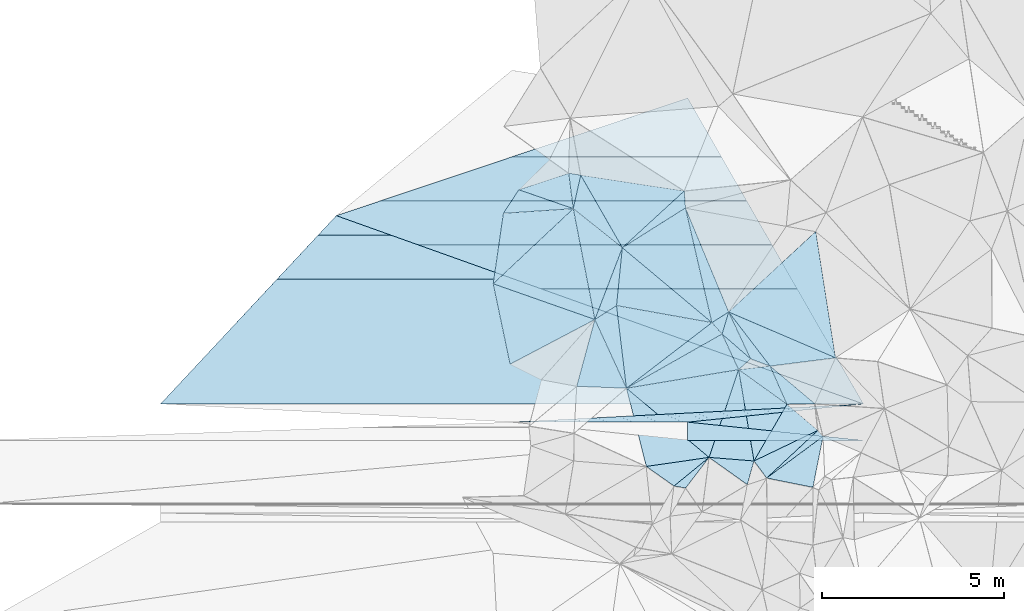
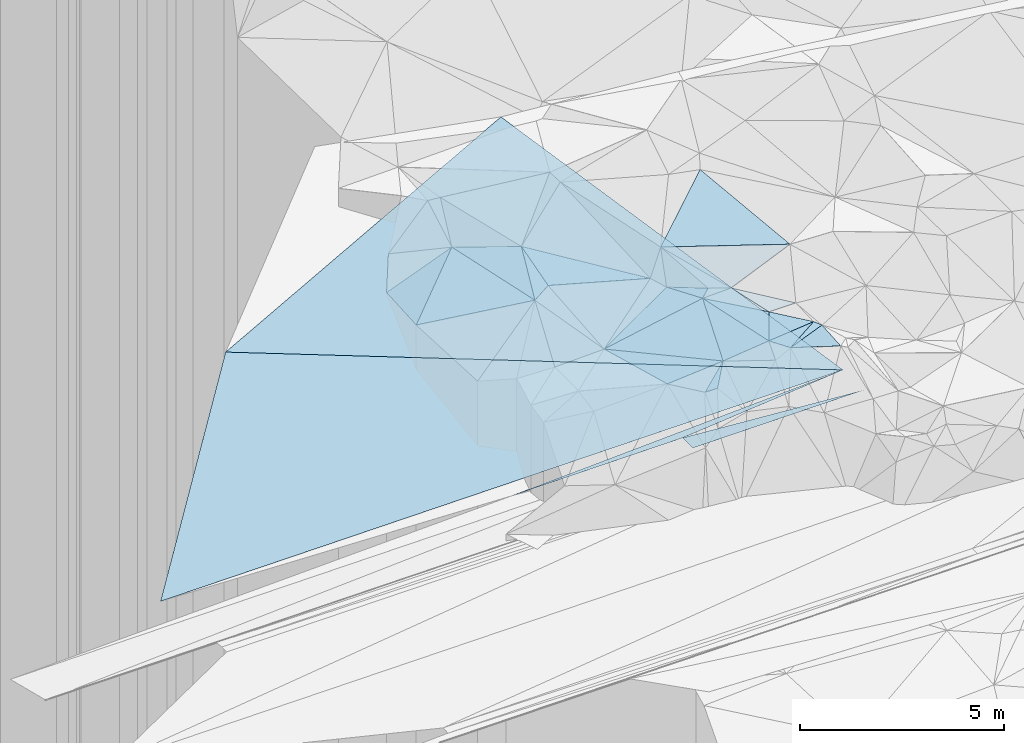
# One storey, part 67 of 275: 50 plates.
"""IFC2X3 building model written with IfcOpenShell, lengths in millimetres."""

from ifc_helpers import new_model, si_unit, frame, origin_with_axes, place, context, subcontext, project, spatial, polyline, outline, extrude, material, type_object, element, save


model = new_model("IFC2X3")

# Units and contexts
model_context = context("Model", 3, precision=1e-05, world=origin_with_axes())
body_context = subcontext(model_context, "Body", "Model", "MODEL_VIEW")
ifc_project = project(units=[si_unit("LENGTHUNIT", "METRE", prefix="MILLI"), si_unit("AREAUNIT", "SQUARE_METRE"), si_unit("VOLUMEUNIT", "CUBIC_METRE"), si_unit("MASSUNIT", "GRAM", prefix="KILO"), si_unit("TIMEUNIT", "SECOND"), si_unit("PLANEANGLEUNIT", "RADIAN"), si_unit("SOLIDANGLEUNIT", "STERADIAN"), si_unit("THERMODYNAMICTEMPERATUREUNIT", "DEGREE_CELSIUS"), si_unit("LUMINOUSINTENSITYUNIT", "LUMEN")], contexts=[model_context])

# Site, building, storey
site_placement = place(None, origin_with_axes())
site = spatial("IfcSite", under=ifc_project, at=site_placement, CompositionType="ELEMENT")
building_placement = place(site_placement, origin_with_axes())
building = spatial("IfcBuilding", under=site, at=building_placement, Name="Undefined", CompositionType="ELEMENT")
storey_placement = place(building_placement, origin_with_axes())
storey = spatial("IfcBuildingStorey", under=building, at=storey_placement, Name="Undefined", CompositionType="ELEMENT", Elevation=0.0)

# Plates
ifc_material = material()
plate_type_1 = type_object("IfcPlateType", PredefinedType="NOTDEFINED")
for number, where, z_axis, x_axis, name in (
    (1, (-129444.335760061, 69294.3090173792, 48443.6810089496), (0.00832550512650313, -4.76525014343269e-07, -0.999965342381505), (-0.994665412446994, -0.102820903085224, -0.00828125415566605), "00_PR"),
    (2, (-129444.335760061, 69294.3090173792, 48443.6810089496), (0.00832550512650313, -4.76525014343269e-07, -0.999965342381505), (-0.994665412446994, -0.102820903085224, -0.00828125415566605), "00_PR"),
    (3, (-129444.335760061, 69294.3090173792, 48443.6810089496), (0.00832550512650313, -4.76525014343269e-07, -0.999965342381505), (-0.994665412446994, -0.102820903085224, -0.00828125415566605), "00_PR"),
):
    element("IfcPlate", number, at=place(storey_placement, frame(where, z_axis=z_axis, x_axis=x_axis)), inside=storey, type_object=plate_type_1, material=ifc_material, Name=name, context=body_context, shape_type="SweptSolid", body=[
        extrude(outline(polyline([(0.0, 0.0), (4860.13330078125, -1.09284883365035e-08), (9668.8271484375, 497.347320556641), (0.0, 0.0)])), frame((-8.85201319254618e-08, 2.18876761149539e-07, -0.5000001331573), z_axis=(0.0, 0.0, 1.0), x_axis=(1.0, 0.0, 0.0)), (0.0, 0.0, 1.0), 1.0),
    ])
plate_type_2 = type_object("IfcPlateType", PredefinedType="NOTDEFINED")
plate_1_placement = place(storey_placement, frame((-133151.568710106, 71824.4536752865, 51889.7082125134), z_axis=(0.578569093147752, 0.569869113096198, -0.583529775069911), x_axis=(0.384124780186337, -0.821500114876662, -0.421409200782837)))
element("IfcPlate", 4, at=plate_1_placement, inside=storey, type_object=plate_type_2, material=ifc_material, Name="00", context=body_context, shape_type="SweptSolid", body=[
    extrude(outline(polyline([(0.0, 0.0), (1566.17370605469, -5.5297277867794e-10), (751.832336425781, 652.800231933594), (0.0, 0.0)])), frame((-8.85201319254618e-08, 2.18876761149539e-07, -0.5000001331573), z_axis=(0.0, 0.0, 1.0), x_axis=(1.0, 0.0, 0.0)), (0.0, 0.0, 1.0), 1.0),
])
plate_type_3 = type_object("IfcPlateType", PredefinedType="NOTDEFINED")
plate_2_placement = place(storey_placement, frame((-136832.977407611, 71618.2938263734, 51709.5212023326), z_axis=(-0.156077399561047, 0.242364993441896, -0.957548461071381), x_axis=(0.840750067986882, 0.541423423191178, 1.24122210420389e-10)))
element("IfcPlate", 5, at=plate_2_placement, inside=storey, type_object=plate_type_3, material=ifc_material, Name="00", context=body_context, shape_type="SweptSolid", body=[
    extrude(outline(polyline([(0.0, 0.0), (708.590148925781, 6.98491930961609e-10), (-293.258392333984, 2150.74389648438), (0.0, 0.0)])), frame((-8.85201319254618e-08, 2.18876761149539e-07, -0.5000001331573), z_axis=(0.0, 0.0, 1.0), x_axis=(1.0, 0.0, 0.0)), (0.0, 0.0, 1.0), 1.0),
])
plate_type_4 = type_object("IfcPlateType", PredefinedType="NOTDEFINED")
plate_3_placement = place(storey_placement, frame((-139629.114113772, 72601.3486087522, 51349.5338180711), z_axis=(0.308443297718231, -0.188807443048331, -0.932316728125295), x_axis=(0.141282109827819, 0.978326261785137, -0.151383919040691)))
element("IfcPlate", 6, at=plate_3_placement, inside=storey, type_object=plate_type_4, material=ifc_material, Name="00", context=body_context, shape_type="SweptSolid", body=[
    extrude(outline(polyline([(0.0, 0.0), (1981.71643066406, -9.42964106798172e-09), (2286.40185546875, 1997.74047851563), (0.0, 0.0)])), frame((-8.85201319254618e-08, 2.18876761149539e-07, -0.5000001331573), z_axis=(0.0, 0.0, 1.0), x_axis=(1.0, 0.0, 0.0)), (0.0, 0.0, 1.0), 1.0),
])
plate_type_5 = type_object("IfcPlateType", PredefinedType="NOTDEFINED")
for number, where, z_axis, x_axis, name in (
    (7, (-134278.542476216, 68794.5856960498, 48403.4330086572), (0.00832550512650313, -4.76525014343269e-07, -0.999965342381505), (0.994653635899512, -0.102934762941165, 0.00828125413975662), "00_PR"),
    (8, (-134278.542476216, 68794.5856960498, 48403.4330086572), (0.00832550512650313, -4.76525014343269e-07, -0.999965342381505), (0.994653635899512, -0.102934762941165, 0.00828125413975662), "00_PR"),
    (9, (-134278.542476216, 68794.5856960498, 48403.4330086572), (0.00832550512650313, -4.76525014343269e-07, -0.999965342381505), (0.994653635899512, -0.102934762941165, 0.00828125413975662), "00_PR"),
):
    element("IfcPlate", number, at=place(storey_placement, frame(where, z_axis=z_axis, x_axis=x_axis)), inside=storey, type_object=plate_type_5, material=ifc_material, Name=name, context=body_context, shape_type="SweptSolid", body=[
        extrude(outline(polyline([(0.0, 0.0), (4860.13330078125, -1.09284883365035e-08), (51.4388885498047, 497.347015380859), (0.0, 0.0)])), frame((-8.85201319254618e-08, 2.18876761149539e-07, -0.5000001331573), z_axis=(0.0, 0.0, 1.0), x_axis=(1.0, 0.0, 0.0)), (0.0, 0.0, 1.0), 1.0),
    ])
plate_type_6 = type_object("IfcPlateType", PredefinedType="NOTDEFINED")
plate_4_placement = place(storey_placement, frame((-132455.381157078, 67725.8258750674, 51319.5189506948), z_axis=(-0.257117366696201, -0.0910848269011181, -0.962078070663501), x_axis=(0.491212129687277, 0.845027332798837, -0.211280501871263)))
element("IfcPlate", 10, at=plate_4_placement, inside=storey, type_object=plate_type_6, material=ifc_material, Name="00", context=body_context, shape_type="SweptSolid", body=[
    extrude(outline(polyline([(0.0, 0.0), (1845.88732910156, 1.36205926537514e-08), (1693.00695800781, 1114.59753417969), (0.0, 0.0)])), frame((-8.85201319254618e-08, 2.18876761149539e-07, -0.5000001331573), z_axis=(0.0, 0.0, 1.0), x_axis=(1.0, 0.0, 0.0)), (0.0, 0.0, 1.0), 1.0),
])
plate_type_7 = type_object("IfcPlateType", PredefinedType="NOTDEFINED")
plate_5_placement = place(storey_placement, frame((-130556.349028885, 68401.3227740387, 50719.5199078316), z_axis=(-0.21672475804509, -0.176393568784046, -0.960164406829333), x_axis=(-0.189118695865837, -0.95732243317476, 0.21855863701616)))
element("IfcPlate", 11, at=plate_5_placement, inside=storey, type_object=plate_type_7, material=ifc_material, Name="00", context=body_context, shape_type="SweptSolid", body=[
    extrude(outline(polyline([(0.0, 0.0), (1464.13793945313, -5.76255843043327e-09), (1510.92321777344, 1319.66333007813), (0.0, 0.0)])), frame((-8.85201319254618e-08, 2.18876761149539e-07, -0.5000001331573), z_axis=(0.0, 0.0, 1.0), x_axis=(1.0, 0.0, 0.0)), (0.0, 0.0, 1.0), 1.0),
])
plate_type_8 = type_object("IfcPlateType", PredefinedType="NOTDEFINED")
plate_6_placement = place(storey_placement, frame((-133613.467629506, 71532.7080362273, 51289.5076855455), z_axis=(-0.138507740364616, 0.106817498638844, -0.984583987196435), x_axis=(-0.972387778428098, 0.173877071909719, 0.155655941832529)))
element("IfcPlate", 12, at=plate_6_placement, inside=storey, type_object=plate_type_8, material=ifc_material, Name="00", context=body_context, shape_type="SweptSolid", body=[
    extrude(outline(polyline([(0.0, 0.0), (2698.2587890625, -4.40195435658097e-09), (2842.12915039063, 1599.37524414063), (0.0, 0.0)])), frame((-8.85201319254618e-08, 2.18876761149539e-07, -0.5000001331573), z_axis=(0.0, 0.0, 1.0), x_axis=(1.0, 0.0, 0.0)), (0.0, 0.0, 1.0), 1.0),
])
plate_type_9 = type_object("IfcPlateType", PredefinedType="NOTDEFINED")
for number, where, z_axis, x_axis, name in (
    (13, (-134278.031319056, 77711.906399942, 52612.0347901704), (0.00747221277555471, 0.447200796920443, -0.894402377719311), (0.457576437903009, -0.79682143765692, -0.394587632809689), "00_PR"),
    (14, (-134278.031319056, 77711.906399942, 52612.0347901704), (0.00747221277555471, 0.447200796920443, -0.894402377719311), (0.457576437903009, -0.79682143765692, -0.394587632809689), "00_PR"),
    (15, (-134278.031319056, 77711.906399942, 52612.0347901704), (0.00747221277555471, 0.447200796920443, -0.894402377719311), (0.457576437903009, -0.79682143765692, -0.394587632809689), "00_PR"),
):
    element("IfcPlate", number, at=place(storey_placement, frame(where, z_axis=z_axis, x_axis=x_axis)), inside=storey, type_object=plate_type_9, material=ifc_material, Name=name, context=body_context, shape_type="SweptSolid", body=[
        extrude(outline(polyline([(0.0, 0.0), (10563.6884765625, 9.62900230661035e-08), (-1175.76281738281, 10268.96875), (0.0, 0.0)])), frame((-8.85201319254618e-08, 2.18876761149539e-07, -0.5000001331573), z_axis=(0.0, 0.0, 1.0), x_axis=(1.0, 0.0, 0.0)), (0.0, 0.0, 1.0), 1.0),
    ])
plate_type_10 = type_object("IfcPlateType", PredefinedType="NOTDEFINED")
for number, where, z_axis, x_axis, name in (
    (16, (-143946.572280143, 74476.4051419111, 50913.5097885853), (0.00747221277555471, 0.447200796920443, -0.894402377719311), (0.929809253918933, -0.332235179916425, -0.158349412858456), "00_PR"),
    (17, (-143946.572280143, 74476.4051419111, 50913.5097885853), (0.00747221277555471, 0.447200796920443, -0.894402377719311), (0.929809253918933, -0.332235179916425, -0.158349412858456), "00_PR"),
    (18, (-143946.572280143, 74476.4051419111, 50913.5097885853), (0.00747221277555471, 0.447200796920443, -0.894402377719311), (0.929809253918933, -0.332235179916425, -0.158349412858456), "00_PR"),
):
    element("IfcPlate", number, at=place(storey_placement, frame(where, z_axis=z_axis, x_axis=x_axis)), inside=storey, type_object=plate_type_10, material=ifc_material, Name=name, context=body_context, shape_type="SweptSolid", body=[
        extrude(outline(polyline([(0.0, 0.0), (15597.0009765625, 2.149427018594e-07), (-2357.32592773438, 7181.6728515625), (0.0, 0.0)])), frame((-8.85201319254618e-08, 2.18876761149539e-07, -0.5000001331573), z_axis=(0.0, 0.0, 1.0), x_axis=(1.0, 0.0, 0.0)), (0.0, 0.0, 1.0), 1.0),
    ])
plate_type_11 = type_object("IfcPlateType", PredefinedType="NOTDEFINED")
plate_7_placement = place(storey_placement, frame((-133151.816142031, 71824.4115064714, 51889.564875314), z_axis=(0.0836998194778829, 0.485530176066707, -0.87020387746091), x_axis=(0.567438192009801, -0.741080066702904, -0.358906997680829)))
element("IfcPlate", 19, at=plate_7_placement, inside=storey, type_object=plate_type_11, material=ifc_material, Name="00", context=body_context, shape_type="SweptSolid", body=[
    extrude(outline(polyline([(0.0, 0.0), (2006.09069824219, -7.97444954514503e-09), (1531.7353515625, 326.629669189453), (0.0, 0.0)])), frame((-8.85201319254618e-08, 2.18876761149539e-07, -0.5000001331573), z_axis=(0.0, 0.0, 1.0), x_axis=(1.0, 0.0, 0.0)), (0.0, 0.0, 1.0), 1.0),
])
plate_8_placement = place(storey_placement, frame((-137550.911538059, 75641.7072257303, 52509.6304337484), z_axis=(0.125923898845436, 0.661737767247199, -0.739084771253106), x_axis=(0.987554178420032, -0.154385981863647, 0.0300285412421723)))
element("IfcPlate", 20, at=plate_8_placement, inside=storey, type_object=plate_type_11, material=ifc_material, Name="00", context=body_context, shape_type="SweptSolid", body=[
    extrude(outline(polyline([(0.0, 0.0), (333.016510009766, -2.69938027486205e-09), (247.134887695313, 1274.13671875), (0.0, 0.0)])), frame((-8.85201319254618e-08, 2.18876761149539e-07, -0.5000001331573), z_axis=(0.0, 0.0, 1.0), x_axis=(1.0, 0.0, 0.0)), (0.0, 0.0, 1.0), 1.0),
])
plate_type_12 = type_object("IfcPlateType", PredefinedType="NOTDEFINED")
plate_9_placement = place(storey_placement, frame((-131548.53847023, 69285.8044596213, 50929.5118166729), z_axis=(-0.0162222852816824, 0.215611132485444, -0.976344548306889), x_axis=(-0.395815804271746, 0.895317677054343, 0.204294165953721)))
element("IfcPlate", 21, at=plate_9_placement, inside=storey, type_object=plate_type_12, material=ifc_material, Name="00", context=body_context, shape_type="SweptSolid", body=[
    extrude(outline(polyline([(0.0, 0.0), (1174.77661132813, -1.32131390273571e-08), (-295.715789794922, 711.865295410156), (0.0, 0.0)])), frame((-8.85201319254618e-08, 2.18876761149539e-07, -0.5000001331573), z_axis=(0.0, 0.0, 1.0), x_axis=(1.0, 0.0, 0.0)), (0.0, 0.0, 1.0), 1.0),
])
plate_type_13 = type_object("IfcPlateType", PredefinedType="NOTDEFINED")
plate_10_placement = place(storey_placement, frame((-132106.04716172, 67257.1091079404, 51279.5295421955), z_axis=(-0.338692955504805, -0.00179162069924216, -0.940895250273212), x_axis=(0.707636187632108, 0.658577823877607, -0.255981006815216)))
element("IfcPlate", 22, at=plate_10_placement, inside=storey, type_object=plate_type_13, material=ifc_material, Name="00", context=body_context, shape_type="SweptSolid", body=[
    extrude(outline(polyline([(0.0, 0.0), (1992.33532714844, 6.98491930961609e-09), (1993.53991699219, 224.050323486328), (0.0, 0.0)])), frame((-8.85201319254618e-08, 2.18876761149539e-07, -0.5000001331573), z_axis=(0.0, 0.0, 1.0), x_axis=(1.0, 0.0, 0.0)), (0.0, 0.0, 1.0), 1.0),
])
plate_type_14 = type_object("IfcPlateType", PredefinedType="NOTDEFINED")
plate_11_placement = place(storey_placement, frame((-132877.817774374, 70239.7820043523, 51219.5105403268), z_axis=(-0.0780078698748302, 0.18887847276813, -0.978897182937192), x_axis=(0.992019358560659, 0.112266578159073, -0.0573917038373246)))
element("IfcPlate", 23, at=plate_11_placement, inside=storey, type_object=plate_type_14, material=ifc_material, Name="00", context=body_context, shape_type="SweptSolid", body=[
    extrude(outline(polyline([(0.0, 0.0), (871.2060546875, -1.04628270491958e-08), (1228.18249511719, 1119.22644042969), (0.0, 0.0)])), frame((-8.85201319254618e-08, 2.18876761149539e-07, -0.5000001331573), z_axis=(0.0, 0.0, 1.0), x_axis=(1.0, 0.0, 0.0)), (0.0, 0.0, 1.0), 1.0),
])
plate_type_15 = type_object("IfcPlateType", PredefinedType="NOTDEFINED")
plate_12_placement = place(storey_placement, frame((-134340.991182013, 74687.9575510025, 52519.663516732), z_axis=(0.618913487642724, 0.405122106723485, -0.672920629389413), x_axis=(0.375913067278865, -0.90501168211732, -0.199106054855635)))
element("IfcPlate", 24, at=plate_12_placement, inside=storey, type_object=plate_type_15, material=ifc_material, Name="00", context=body_context, shape_type="SweptSolid", body=[
    extrude(outline(polyline([(0.0, 0.0), (3164.14282226563, 8.60745785757899e-09), (3373.93115234375, 783.574401855469), (0.0, 0.0)])), frame((-8.85201319254618e-08, 2.18876761149539e-07, -0.5000001331573), z_axis=(0.0, 0.0, 1.0), x_axis=(1.0, 0.0, 0.0)), (0.0, 0.0, 1.0), 1.0),
])
plate_type_16 = type_object("IfcPlateType", PredefinedType="NOTDEFINED")
plate_13_placement = place(storey_placement, frame((-133690.675106162, 67824.7548051344, 51089.5038394862), z_axis=(0.124030191897327, -0.000639775856149848, -0.992278238290434), x_axis=(-0.605796608680316, -0.79205666488973, -0.0752110930327854)))
element("IfcPlate", 25, at=plate_13_placement, inside=storey, type_object=plate_type_16, material=ifc_material, Name="00", context=body_context, shape_type="SweptSolid", body=[
    extrude(outline(polyline([(0.0, 0.0), (1063.6728515625, 3.69618646800518e-09), (1216.44543457031, 289.068420410156), (0.0, 0.0)])), frame((-8.85201319254618e-08, 2.18876761149539e-07, -0.5000001331573), z_axis=(0.0, 0.0, 1.0), x_axis=(1.0, 0.0, 0.0)), (0.0, 0.0, 1.0), 1.0),
])
plate_type_17 = type_object("IfcPlateType", PredefinedType="NOTDEFINED")
plate_14_placement = place(storey_placement, frame((-136076.682338519, 73592.6054063525, 51859.5035352943), z_axis=(-0.0644820109173179, 0.100130974435352, -0.992882600424988), x_axis=(-0.0999494008353778, -0.990598198375528, -0.0934094569506024)))
element("IfcPlate", 26, at=plate_14_placement, inside=storey, type_object=plate_type_17, material=ifc_material, Name="00", context=body_context, shape_type="SweptSolid", body=[
    extrude(outline(polyline([(0.0, 0.0), (1605.83312988281, 4.13274392485619e-09), (2045.41796875, 555.75634765625), (0.0, 0.0)])), frame((-8.85201319254618e-08, 2.18876761149539e-07, -0.5000001331573), z_axis=(0.0, 0.0, 1.0), x_axis=(1.0, 0.0, 0.0)), (0.0, 0.0, 1.0), 1.0),
])
plate_type_18 = type_object("IfcPlateType", PredefinedType="NOTDEFINED")
plate_15_placement = place(storey_placement, frame((-132638.179358679, 67076.4709224785, 51199.513280691), z_axis=(0.191293809768911, 0.125948832050666, -0.973418496870266), x_axis=(-0.812040488591794, 0.577396749484676, -0.0848718950662146)))
element("IfcPlate", 27, at=plate_15_placement, inside=storey, type_object=plate_type_18, material=ifc_material, Name="00", context=body_context, shape_type="SweptSolid", body=[
    extrude(outline(polyline([(0.0, 0.0), (1296.07104492188, 4.29645297117531e-09), (216.191864013672, 650.354553222656), (0.0, 0.0)])), frame((-8.85201319254618e-08, 2.18876761149539e-07, -0.5000001331573), z_axis=(0.0, 0.0, 1.0), x_axis=(1.0, 0.0, 0.0)), (0.0, 0.0, 1.0), 1.0),
])
plate_type_19 = type_object("IfcPlateType", PredefinedType="NOTDEFINED")
plate_16_placement = place(storey_placement, frame((-138924.505467017, 75187.4952364488, 51669.6400413276), z_axis=(0.222872252286444, 0.657327724178088, -0.719894591025397), x_axis=(0.821084321078671, 0.271500444220018, 0.502103621244769)))
element("IfcPlate", 28, at=plate_16_placement, inside=storey, type_object=plate_type_19, material=ifc_material, Name="00", context=body_context, shape_type="SweptSolid", body=[
    extrude(outline(polyline([(0.0, 0.0), (1672.96142578125, 1.88592821359634e-08), (1083.82653808594, 1156.46875), (0.0, 0.0)])), frame((-8.85201319254618e-08, 2.18876761149539e-07, -0.5000001331573), z_axis=(0.0, 0.0, 1.0), x_axis=(1.0, 0.0, 0.0)), (0.0, 0.0, 1.0), 1.0),
])
plate_type_20 = type_object("IfcPlateType", PredefinedType="NOTDEFINED")
plate_17_placement = place(storey_placement, frame((-136076.596303396, 73592.7466117941, 51859.5411646223), z_axis=(0.107569654708381, 0.382557604187509, -0.917648325266402), x_axis=(0.805052073835681, 0.508077923158314, 0.306182923122769)))
element("IfcPlate", 29, at=plate_17_placement, inside=storey, type_object=plate_type_20, material=ifc_material, Name="00", context=body_context, shape_type="SweptSolid", body=[
    extrude(outline(polyline([(0.0, 0.0), (2155.57421875, 1.74331944435835e-08), (761.931579589844, 3170.9873046875), (0.0, 0.0)])), frame((-8.85201319254618e-08, 2.18876761149539e-07, -0.5000001331573), z_axis=(0.0, 0.0, 1.0), x_axis=(1.0, 0.0, 0.0)), (0.0, 0.0, 1.0), 1.0),
])
plate_type_21 = type_object("IfcPlateType", PredefinedType="NOTDEFINED")
plate_18_placement = place(storey_placement, frame((-136076.39231152, 73592.8156075522, 51859.6596816225), z_axis=(0.515552462072122, 0.520547771519965, -0.680614190578606), x_axis=(-0.776912665052063, 0.619003734784327, -0.11506992311093)))
element("IfcPlate", 30, at=plate_18_placement, inside=storey, type_object=plate_type_21, material=ifc_material, Name="00", context=body_context, shape_type="SweptSolid", body=[
    extrude(outline(polyline([(0.0, 0.0), (1738.07360839844, -2.895831130445e-09), (2050.37353515625, 1238.25231933594), (0.0, 0.0)])), frame((-8.85201319254618e-08, 2.18876761149539e-07, -0.5000001331573), z_axis=(0.0, 0.0, 1.0), x_axis=(1.0, 0.0, 0.0)), (0.0, 0.0, 1.0), 1.0),
])
plate_type_22 = type_object("IfcPlateType", PredefinedType="NOTDEFINED")
plate_19_placement = place(storey_placement, frame((-133332.571043139, 71219.7169750417, 51119.6876418317), z_axis=(0.381906982090944, 0.681104363743673, -0.624695047778925), x_axis=(-0.618616169165232, 0.690569645842182, 0.374736706887299)))
element("IfcPlate", 31, at=plate_19_placement, inside=storey, type_object=plate_type_22, material=ifc_material, Name="00", context=body_context, shape_type="SweptSolid", body=[
    extrude(outline(polyline([(0.0, 0.0), (453.65185546875, 1.86992110684514e-09), (594.288330078125, 798.887573242188), (0.0, 0.0)])), frame((-8.85201319254618e-08, 2.18876761149539e-07, -0.5000001331573), z_axis=(0.0, 0.0, 1.0), x_axis=(1.0, 0.0, 0.0)), (0.0, 0.0, 1.0), 1.0),
])
plate_type_23 = type_object("IfcPlateType", PredefinedType="NOTDEFINED")
plate_20_placement = place(storey_placement, frame((-133332.734707552, 71219.3382850028, 51119.5021935288), z_axis=(0.0545778960888641, -0.0762764203930114, -0.995591864646624), x_axis=(0.419415094254306, -0.90310207508095, 0.0921825400828915)))
element("IfcPlate", 32, at=plate_20_placement, inside=storey, type_object=plate_type_23, material=ifc_material, Name="00", context=body_context, shape_type="SweptSolid", body=[
    extrude(outline(polyline([(0.0, 0.0), (1084.80407714844, -2.6338966563344e-09), (240.412063598633, 3015.49365234375), (0.0, 0.0)])), frame((-8.85201319254618e-08, 2.18876761149539e-07, -0.5000001331573), z_axis=(0.0, 0.0, 1.0), x_axis=(1.0, 0.0, 0.0)), (0.0, 0.0, 1.0), 1.0),
])
plate_type_24 = type_object("IfcPlateType", PredefinedType="NOTDEFINED")
plate_21_placement = place(storey_placement, frame((-132550.208747298, 70537.526153895, 51229.5028003186), z_axis=(0.0862428945176617, -0.0614467250969242, -0.994377424884575), x_axis=(-0.739619210619171, -0.672646622942243, -0.0225819380804684)))
element("IfcPlate", 33, at=plate_21_placement, inside=storey, type_object=plate_type_24, material=ifc_material, Name="00", context=body_context, shape_type="SweptSolid", body=[
    extrude(outline(polyline([(0.0, 0.0), (442.831787109375, 9.60426405072212e-10), (122.619918823242, 1036.46728515625), (0.0, 0.0)])), frame((-8.85201319254618e-08, 2.18876761149539e-07, -0.5000001331573), z_axis=(0.0, 0.0, 1.0), x_axis=(1.0, 0.0, 0.0)), (0.0, 0.0, 1.0), 1.0),
])
plate_type_25 = type_object("IfcPlateType", PredefinedType="NOTDEFINED")
plate_22_placement = place(storey_placement, frame((-132877.76121865, 70239.7085321667, 51219.5007370004), z_axis=(0.0351010522883326, 0.0419348254563774, -0.99850357362515), x_axis=(-0.318630841746835, -0.946508457922298, -0.0509521910152792)))
element("IfcPlate", 34, at=plate_22_placement, inside=storey, type_object=plate_type_25, material=ifc_material, Name="00", context=body_context, shape_type="SweptSolid", body=[
    extrude(outline(polyline([(0.0, 0.0), (2551.41137695313, -3.20142135024071e-10), (1474.51721191406, 2762.60717773438), (0.0, 0.0)])), frame((-8.85201319254618e-08, 2.18876761149539e-07, -0.5000001331573), z_axis=(0.0, 0.0, 1.0), x_axis=(1.0, 0.0, 0.0)), (0.0, 0.0, 1.0), 1.0),
])
plate_type_26 = type_object("IfcPlateType", PredefinedType="NOTDEFINED")
plate_23_placement = place(storey_placement, frame((-136832.79339206, 71618.3014419332, 51709.5286291509), z_axis=(0.21194385698298, 0.257603815857771, -0.942719510534652), x_axis=(-0.841229856623277, -0.442878895031367, -0.310146115018994)))
element("IfcPlate", 35, at=plate_23_placement, inside=storey, type_object=plate_type_26, material=ifc_material, Name="00", context=body_context, shape_type="SweptSolid", body=[
    extrude(outline(polyline([(0.0, 0.0), (2772.88647460938, 1.158332452178e-08), (2028.57202148438, 2191.11743164063), (0.0, 0.0)])), frame((-8.85201319254618e-08, 2.18876761149539e-07, -0.5000001331573), z_axis=(0.0, 0.0, 1.0), x_axis=(1.0, 0.0, 0.0)), (0.0, 0.0, 1.0), 1.0),
])
plate_type_27 = type_object("IfcPlateType", PredefinedType="NOTDEFINED")
plate_24_placement = place(storey_placement, frame((-135964.517145618, 69728.089341981, 51089.5383395049), z_axis=(-0.181353834824113, 0.338569356831128, -0.923299289076703), x_axis=(0.791434954798146, 0.607534218100343, 0.0673267120900804)))
element("IfcPlate", 36, at=plate_24_placement, inside=storey, type_object=plate_type_27, material=ifc_material, Name="00", context=body_context, shape_type="SweptSolid", body=[
    extrude(outline(polyline([(0.0, 0.0), (2970.58911132813, -1.65891833603382e-09), (2990.921875, 453.195953369141), (0.0, 0.0)])), frame((-8.85201319254618e-08, 2.18876761149539e-07, -0.5000001331573), z_axis=(0.0, 0.0, 1.0), x_axis=(1.0, 0.0, 0.0)), (0.0, 0.0, 1.0), 1.0),
])
plate_type_28 = type_object("IfcPlateType", PredefinedType="NOTDEFINED")
plate_25_placement = place(storey_placement, frame((-135964.389217526, 69728.0908242119, 51089.5315330833), z_axis=(0.0745001193972009, 0.341534614890433, -0.936911863006039), x_axis=(-0.997139932212472, 0.0374931388115376, -0.0656217961455331)))
element("IfcPlate", 37, at=plate_25_placement, inside=storey, type_object=plate_type_28, material=ifc_material, Name="00", context=body_context, shape_type="SweptSolid", body=[
    extrude(outline(polyline([(0.0, 0.0), (1371.49548339844, 6.44649844616652e-09), (896.174987792969, 1977.01049804688), (0.0, 0.0)])), frame((-8.85201319254618e-08, 2.18876761149539e-07, -0.5000001331573), z_axis=(0.0, 0.0, 1.0), x_axis=(1.0, 0.0, 0.0)), (0.0, 0.0, 1.0), 1.0),
])
plate_type_29 = type_object("IfcPlateType", PredefinedType="NOTDEFINED")
plate_26_placement = place(storey_placement, frame((-133690.773937177, 67824.8740540164, 51089.5157376461), z_axis=(-0.0736285828747129, 0.237862376986857, -0.968504166949231), x_axis=(-0.771078793293006, -0.629465019492925, -0.0959754331512654)))
element("IfcPlate", 38, at=plate_26_placement, inside=storey, type_object=plate_type_29, material=ifc_material, Name="00", context=body_context, shape_type="SweptSolid", body=[
    extrude(outline(polyline([(0.0, 0.0), (1250.31994628906, -4.88944351673126e-09), (1481.62072753906, 923.579956054688), (0.0, 0.0)])), frame((-8.85201319254618e-08, 2.18876761149539e-07, -0.5000001331573), z_axis=(0.0, 0.0, 1.0), x_axis=(1.0, 0.0, 0.0)), (0.0, 0.0, 1.0), 1.0),
])
plate_type_30 = type_object("IfcPlateType", PredefinedType="NOTDEFINED")
plate_27_placement = place(storey_placement, frame((-133690.754386191, 67824.7345015921, 51089.5007024325), z_axis=(-0.0345251047929108, -0.041246747555001, -0.998552313579601), x_axis=(-0.988929559794793, -0.142866440136178, 0.0400937158030124)))
element("IfcPlate", 39, at=plate_27_placement, inside=storey, type_object=plate_type_30, material=ifc_material, Name="00", context=body_context, shape_type="SweptSolid", body=[
    extrude(outline(polyline([(0.0, 0.0), (1745.90954589844, -2.16823536902666e-09), (1976.62023925781, 2210.12963867188), (0.0, 0.0)])), frame((-8.85201319254618e-08, 2.18876761149539e-07, -0.5000001331573), z_axis=(0.0, 0.0, 1.0), x_axis=(1.0, 0.0, 0.0)), (0.0, 0.0, 1.0), 1.0),
])
plate_type_31 = type_object("IfcPlateType", PredefinedType="NOTDEFINED")
plate_28_placement = place(storey_placement, frame((-132455.161426161, 67725.8671895323, 51319.5083801317), z_axis=(0.182356353827204, -0.00846095212143459, -0.983196100738833), x_axis=(-0.980080382564674, 0.0784420827875317, -0.182453510132957)))
element("IfcPlate", 40, at=plate_28_placement, inside=storey, type_object=plate_type_31, material=ifc_material, Name="00", context=body_context, shape_type="SweptSolid", body=[
    extrude(outline(polyline([(0.0, 0.0), (1260.59509277344, -9.24046617001295e-10), (629.5439453125, 2472.1396484375), (0.0, 0.0)])), frame((-8.85201319254618e-08, 2.18876761149539e-07, -0.5000001331573), z_axis=(0.0, 0.0, 1.0), x_axis=(1.0, 0.0, 0.0)), (0.0, 0.0, 1.0), 1.0),
])
plate_type_32 = type_object("IfcPlateType", PredefinedType="NOTDEFINED")
plate_29_placement = place(storey_placement, frame((-136832.833931534, 71618.1772635216, 51709.5042989558), z_axis=(0.130874317705118, 0.00923932006506223, -0.991355913852313), x_axis=(-0.936498331721306, 0.329295264708645, -0.120563275186413)))
element("IfcPlate", 41, at=plate_29_placement, inside=storey, type_object=plate_type_32, material=ifc_material, Name="00", context=body_context, shape_type="SweptSolid", body=[
    extrude(outline(polyline([(0.0, 0.0), (2985.98388671875, -3.57504177372903e-08), (1566.82019042969, 2684.1337890625), (0.0, 0.0)])), frame((-8.85201319254618e-08, 2.18876761149539e-07, -0.5000001331573), z_axis=(0.0, 0.0, 1.0), x_axis=(1.0, 0.0, 0.0)), (0.0, 0.0, 1.0), 1.0),
])
plate_type_33 = type_object("IfcPlateType", PredefinedType="NOTDEFINED")
plate_30_placement = place(storey_placement, frame((-130211.760746358, 70565.7253251673, 51709.5876881559), z_axis=(0.179249829697097, 0.536596594524193, -0.82458085916337), x_axis=(-0.950940742456017, -0.120320515262794, -0.285016978343564)))
element("IfcPlate", 42, at=plate_30_placement, inside=storey, type_object=plate_type_33, material=ifc_material, Name="00", context=body_context, shape_type="SweptSolid", body=[
    extrude(outline(polyline([(0.0, 0.0), (1894.6240234375, 2.3283064365387e-10), (2593.02124023438, 1880.59606933594), (0.0, 0.0)])), frame((-8.85201319254618e-08, 2.18876761149539e-07, -0.5000001331573), z_axis=(0.0, 0.0, 1.0), x_axis=(1.0, 0.0, 0.0)), (0.0, 0.0, 1.0), 1.0),
])
plate_type_34 = type_object("IfcPlateType", PredefinedType="NOTDEFINED")
plate_31_placement = place(storey_placement, frame((-130696.154599761, 68569.165504044, 50769.5187833873), z_axis=(-0.250681009349358, -0.104714323881311, -0.962389703771641), x_axis=(-0.707636187673194, -0.658577823831937, 0.255981006819136)))
element("IfcPlate", 43, at=plate_31_placement, inside=storey, type_object=plate_type_34, material=ifc_material, Name="00", context=body_context, shape_type="SweptSolid", body=[
    extrude(outline(polyline([(0.0, 0.0), (1992.33532714844, 6.98491930961609e-09), (1941.0888671875, 583.758361816406), (0.0, 0.0)])), frame((-8.85201319254618e-08, 2.18876761149539e-07, -0.5000001331573), z_axis=(0.0, 0.0, 1.0), x_axis=(1.0, 0.0, 0.0)), (0.0, 0.0, 1.0), 1.0),
])
plate_type_35 = type_object("IfcPlateType", PredefinedType="NOTDEFINED")
plate_32_placement = place(storey_placement, frame((-133151.869643724, 71824.2127418569, 51889.50205354), z_axis=(-0.0232939237834529, 0.0880013399700378, -0.995847958916545), x_axis=(0.733245047761978, 0.67861508503568, 0.0428166590774049)))
element("IfcPlate", 44, at=plate_32_placement, inside=storey, type_object=plate_type_35, material=ifc_material, Name="00", context=body_context, shape_type="SweptSolid", body=[
    extrude(outline(polyline([(0.0, 0.0), (3269.75537109375, -1.56578607857227e-08), (1293.85827636719, 2930.244140625), (0.0, 0.0)])), frame((-8.85201319254618e-08, 2.18876761149539e-07, -0.5000001331573), z_axis=(0.0, 0.0, 1.0), x_axis=(1.0, 0.0, 0.0)), (0.0, 0.0, 1.0), 1.0),
])
plate_type_36 = type_object("IfcPlateType", PredefinedType="NOTDEFINED")
plate_33_placement = place(storey_placement, frame((-136832.820453358, 71618.1799215868, 51709.5062982341), z_axis=(0.157836992229361, 0.0145562317703269, -0.987357888508841), x_axis=(-0.191147747189328, 0.981429430046202, -0.0160876531424678)))
element("IfcPlate", 45, at=plate_33_placement, inside=storey, type_object=plate_type_36, material=ifc_material, Name="00", context=body_context, shape_type="SweptSolid", body=[
    extrude(outline(polyline([(0.0, 0.0), (3107.9736328125, -4.00177668780088e-09), (1790.74877929688, 1133.939453125), (0.0, 0.0)])), frame((-8.85201319254618e-08, 2.18876761149539e-07, -0.5000001331573), z_axis=(0.0, 0.0, 1.0), x_axis=(1.0, 0.0, 0.0)), (0.0, 0.0, 1.0), 1.0),
])
plate_type_37 = type_object("IfcPlateType", PredefinedType="NOTDEFINED")
plate_34_placement = place(storey_placement, frame((-138924.51485177, 75187.4686689666, 51669.6148452512), z_axis=(0.204125677746705, 0.604175844373277, -0.77026245965923), x_axis=(0.944903879252181, -0.327287108892959, -0.00630930476892247)))
element("IfcPlate", 46, at=plate_34_placement, inside=storey, type_object=plate_type_37, material=ifc_material, Name="00", context=body_context, shape_type="SweptSolid", body=[
    extrude(outline(polyline([(0.0, 0.0), (1584.96057128906, 6.55563781037927e-09), (-185.619766235352, 974.0869140625), (0.0, 0.0)])), frame((-8.85201319254618e-08, 2.18876761149539e-07, -0.5000001331573), z_axis=(0.0, 0.0, 1.0), x_axis=(1.0, 0.0, 0.0)), (0.0, 0.0, 1.0), 1.0),
])
plate_type_38 = type_object("IfcPlateType", PredefinedType="NOTDEFINED")
plate_35_placement = place(storey_placement, frame((-134372.714525312, 75154.9081766062, 52539.527339968), z_axis=(0.320306983364912, 0.062122678971678, -0.945274673925548), x_axis=(0.0673773522011124, -0.99681432513479, -0.0426789598800173)))
element("IfcPlate", 47, at=plate_35_placement, inside=storey, type_object=plate_type_38, material=ifc_material, Name="00", context=body_context, shape_type="SweptSolid", body=[
    extrude(outline(polyline([(0.0, 0.0), (468.614990234375, -1.94995664060116e-09), (1471.57055664063, 1908.03039550781), (0.0, 0.0)])), frame((-8.85201319254618e-08, 2.18876761149539e-07, -0.5000001331573), z_axis=(0.0, 0.0, 1.0), x_axis=(1.0, 0.0, 0.0)), (0.0, 0.0, 1.0), 1.0),
])
plate_type_39 = type_object("IfcPlateType", PredefinedType="NOTDEFINED")
plate_36_placement = place(storey_placement, frame((-136237.206885526, 72001.9445676546, 51709.5188588171), z_axis=(-0.109464376304576, 0.249234000699302, -0.962236957934827), x_axis=(0.972387778430504, -0.17387707189833, -0.155655941830217)))
element("IfcPlate", 48, at=plate_36_placement, inside=storey, type_object=plate_type_39, material=ifc_material, Name="00", context=body_context, shape_type="SweptSolid", body=[
    extrude(outline(polyline([(0.0, 0.0), (2698.2587890625, -4.40195435658097e-09), (757.080871582031, 2248.60595703125), (0.0, 0.0)])), frame((-8.85201319254618e-08, 2.18876761149539e-07, -0.5000001331573), z_axis=(0.0, 0.0, 1.0), x_axis=(1.0, 0.0, 0.0)), (0.0, 0.0, 1.0), 1.0),
])
plate_type_40 = type_object("IfcPlateType", PredefinedType="NOTDEFINED")
plate_37_placement = place(storey_placement, frame((-132877.913478624, 70239.6458684648, 51219.5202433289), z_axis=(-0.269190971050611, -0.0834138185491813, -0.959467746190498), x_axis=(0.799954125256287, -0.574120651467496, -0.174524711843298)))
element("IfcPlate", 49, at=plate_37_placement, inside=storey, type_object=plate_type_40, material=ifc_material, Name="00", context=body_context, shape_type="SweptSolid", body=[
    extrude(outline(polyline([(0.0, 0.0), (1661.65576171875, -9.02218744158745e-09), (1763.78283691406, 1843.05993652344), (0.0, 0.0)])), frame((-8.85201319254618e-08, 2.18876761149539e-07, -0.5000001331573), z_axis=(0.0, 0.0, 1.0), x_axis=(1.0, 0.0, 0.0)), (0.0, 0.0, 1.0), 1.0),
])
plate_type_41 = type_object("IfcPlateType", PredefinedType="NOTDEFINED")
plate_38_placement = place(storey_placement, frame((-136076.620681057, 73592.7271254356, 51859.5313405852), z_axis=(0.0590418615451646, 0.343560147571472, -0.937272897072112), x_axis=(-0.478215143612625, 0.833898111874636, 0.275543490998198)))
element("IfcPlate", 50, at=plate_38_placement, inside=storey, type_object=plate_type_41, material=ifc_material, Name="00", context=body_context, shape_type="SweptSolid", body=[
    extrude(outline(polyline([(0.0, 0.0), (2395.26611328125, -3.40514816343784e-09), (675.41552734375, 2312.98803710938), (0.0, 0.0)])), frame((-8.85201319254618e-08, 2.18876761149539e-07, -0.5000001331573), z_axis=(0.0, 0.0, 1.0), x_axis=(1.0, 0.0, 0.0)), (0.0, 0.0, 1.0), 1.0),
])

save(model, "model.ifc")
